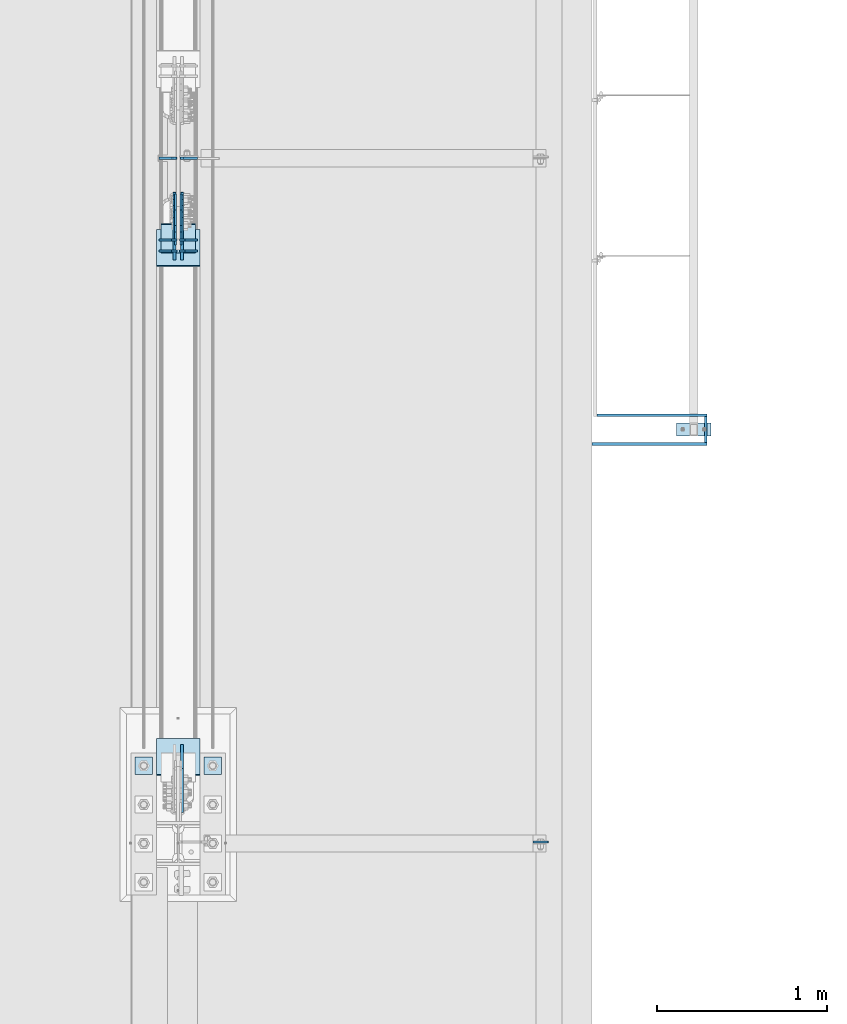
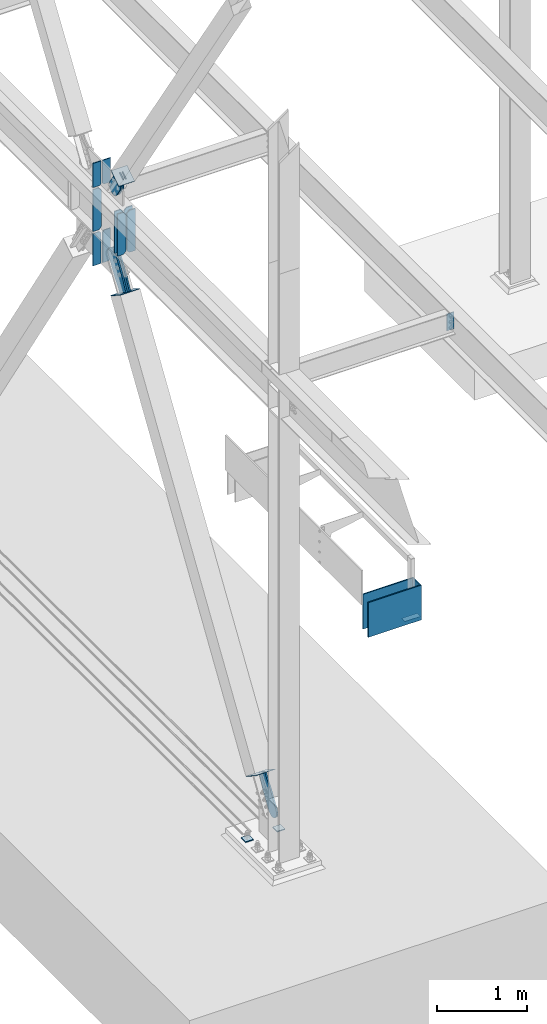
# One storey, part 3331 of 3843: 24 plates, 15 elements without a shape of their own.
"""IFC2X3 building model written with IfcOpenShell, lengths in millimetres."""

from ifc_helpers import new_model, si_unit, frame, origin_with_axes, place, context, subcontext, project, spatial, faceted_brep, material, type_object, element, aggregate, save


model = new_model("IFC2X3")

# Units and contexts
model_context = context("Model", 3, precision=1e-05, world=origin_with_axes())
body_context = subcontext(model_context, "Body", "Model", "MODEL_VIEW")
ifc_project = project(units=[si_unit("LENGTHUNIT", "METRE", prefix="MILLI"), si_unit("AREAUNIT", "SQUARE_METRE"), si_unit("VOLUMEUNIT", "CUBIC_METRE"), si_unit("MASSUNIT", "GRAM", prefix="KILO"), si_unit("TIMEUNIT", "SECOND"), si_unit("PLANEANGLEUNIT", "RADIAN"), si_unit("SOLIDANGLEUNIT", "STERADIAN"), si_unit("THERMODYNAMICTEMPERATUREUNIT", "DEGREE_CELSIUS"), si_unit("LUMINOUSINTENSITYUNIT", "LUMEN")], contexts=[model_context])

# Site, building, storey
site_placement = place(None, origin_with_axes())
site = spatial("IfcSite", under=ifc_project, at=site_placement, CompositionType="ELEMENT")
building_placement = place(site_placement, origin_with_axes())
building = spatial("IfcBuilding", under=site, at=building_placement, Name="Undefined", CompositionType="ELEMENT")
storey_placement = place(building_placement, origin_with_axes())
storey = spatial("IfcBuildingStorey", under=building, at=storey_placement, Name="Undefined", CompositionType="ELEMENT", Elevation=0.0)

# Assembly, plate
assembly_1_placement = place(storey_placement, origin_with_axes())
assembly_1 = element("IfcElementAssembly", 1, at=assembly_1_placement, inside=storey, AssemblyPlace="NOTDEFINED", PredefinedType="NOTDEFINED")
ifc_material_1 = material(Name="Drywall")
plate_type_1 = type_object("IfcPlateType", PredefinedType="NOTDEFINED")
plate_1_placement = place(assembly_1_placement, frame((3101.95308913759, 98996.8516188301, 30714.95), z_axis=(0.999999999468457, -3.26049999966927e-05, 0.0), x_axis=(-3.26049999979655e-05, -0.999999999468457, 0.0)))
plate_1 = element("IfcPlate", 2, at=plate_1_placement, type_object=plate_type_1, material=ifc_material_1, context=body_context, shape_type="Brep", body=[
    faceted_brep([(3.63797880709171e-12, -234.950000000001, -1.45519152283669e-11), (-0.000517728658451233, -234.950000000001, 15.8794303852192), (-0.000517728658451233, 234.950000000001, 15.8794303852192), (3.63797880709171e-12, 234.950000000001, -1.45519152283669e-11), (152.40071802181, -234.950000000001, 15.8843994054114), (152.40071802181, 234.950000000001, 15.8843994054114), (152.401235912494, -234.950000000001, -2.11002770811319e-10), (152.401235912494, 234.950000000001, -2.11002770811319e-10)], [[[0, 1, 2, 3]], [[1, 4, 5, 2]], [[4, 6, 7, 5]], [[6, 0, 3, 7]], [[5, 7, 3, 2]], [[6, 4, 1, 0]]]),
])
aggregate(assembly_1, [plate_1])

assembly_2_placement = place(storey_placement, origin_with_axes())
assembly_2 = element("IfcElementAssembly", 3, at=assembly_2_placement, inside=storey, AssemblyPlace="NOTDEFINED", PredefinedType="NOTDEFINED")
plate_2_placement = place(assembly_2_placement, frame((2438.44525616993, 98828.5999641376, 30714.95), z_axis=(7.63400000505494e-06, 0.999999999970861, 0.0), x_axis=(0.999999999970861, -7.63400000512513e-06, 0.0)))
plate_2 = element("IfcPlate", 4, at=plate_2_placement, type_object=plate_type_1, material=ifc_material_1, context=body_context, shape_type="Brep", body=[
    faceted_brep([(3.63797880709171e-12, -234.950000000001, -1.45519152283669e-11), (-7.41896983527113e-05, -234.950000000001, 15.8794303937975), (-7.41896983527113e-05, 234.950000000001, 15.8794303937975), (3.63797880709171e-12, 234.950000000001, -1.45519152283669e-11), (679.451119685347, -234.950000000001, 15.884399409013), (679.451119685347, 234.950000000001, 15.884399409013), (679.451235852533, -234.950000000001, -4.48198989033699e-09), (679.451235852533, 234.950000000001, -4.48198989033699e-09)], [[[0, 1, 2, 3]], [[1, 4, 5, 2]], [[4, 6, 7, 5]], [[6, 0, 3, 7]], [[5, 7, 3, 2]], [[6, 4, 1, 0]]]),
])
aggregate(assembly_2, [plate_2])

assembly_3_placement = place(storey_placement, origin_with_axes())
assembly_3 = element("IfcElementAssembly", 5, at=assembly_3_placement, inside=storey, AssemblyPlace="NOTDEFINED", PredefinedType="NOTDEFINED")
plate_3_placement = place(assembly_3_placement, frame((2467.02025616993, 98996.8749641376, 30714.95), z_axis=(7.63400000505494e-06, 0.999999999970861, 0.0), x_axis=(0.999999999970861, -7.63400000512513e-06, 0.0)))
plate_3 = element("IfcPlate", 6, at=plate_3_placement, type_object=plate_type_1, material=ifc_material_1, context=body_context, shape_type="Brep", body=[
    faceted_brep([(3.63797880709171e-12, -234.950000000001, -1.45519152283669e-11), (-7.41896983527113e-05, -234.950000000001, 15.8794303937975), (-7.41896983527113e-05, 234.950000000001, 15.8794303937975), (3.63797880709171e-12, 234.950000000001, -1.45519152283669e-11), (650.876114586341, -234.950000000001, 15.884399418268), (650.876114586341, 234.950000000001, 15.884399418268), (650.876235853531, -234.950000000001, 4.65661287307739e-09), (650.876235853531, 234.950000000001, 4.65661287307739e-09)], [[[0, 1, 2, 3]], [[1, 4, 5, 2]], [[4, 6, 7, 5]], [[6, 0, 3, 7]], [[5, 7, 3, 2]], [[6, 4, 1, 0]]]),
])
aggregate(assembly_3, [plate_3])

assembly_4_placement = place(storey_placement, origin_with_axes())
assembly_4 = element("IfcElementAssembly", 7, at=assembly_4_placement, inside=storey, Name="FRAME", AssemblyPlace="NOTDEFINED", PredefinedType="RIGID_FRAME")
ifc_material_2 = material(Name="STEEL/A572-50")
plate_type_2 = type_object("IfcPlateType", PredefinedType="NOTDEFINED")
plate_4_placement = place(assembly_4_placement, frame((3139.678125, 98958.4, 30483.175), z_axis=(0.0, -1.0, 0.0), x_axis=(-1.0, 0.0, 0.0)))
plate_4 = element("IfcPlate", 8, at=plate_4_placement, type_object=plate_type_2, material=ifc_material_2, Name="PLATE", context=body_context, shape_type="Brep", body=[
    faceted_brep([(0.0, -3.17499999999927, 0.0), (0.0, -3.17499999999927, 76.1999969482422), (0.0, 3.17499999999927, 76.1999969482422), (0.0, 3.17499999999927, 0.0), (203.199996948242, -3.17499999999927, 76.1999969482422), (203.199996948242, 3.17499999999927, 76.1999969482422), (203.199996948242, -3.17499999999927, 0.0), (203.199996948242, 3.17499999999927, 0.0)], [[[0, 1, 2, 3]], [[1, 4, 5, 2]], [[4, 6, 7, 5]], [[6, 0, 3, 7]], [[5, 7, 3, 2]], [[6, 4, 1, 0]]]),
])
aggregate(assembly_4, [plate_4])

assembly_5_placement = place(storey_placement, origin_with_axes())
assembly_5 = element("IfcElementAssembly", 9, at=assembly_5_placement, inside=storey, Name="BEAM", AssemblyPlace="NOTDEFINED", PredefinedType="RIGID_FRAME")
plate_type_3 = type_object("IfcPlateType", PredefinedType="NOTDEFINED")
plate_5_placement = place(assembly_5_placement, frame((2180.43125, 96489.8375, 36398.2), z_axis=(-1.0, 0.0, 0.0), x_axis=(0.0, 0.0, -1.0)))
plate_5 = element("IfcPlate", 10, at=plate_5_placement, type_object=plate_type_3, material=ifc_material_2, Name="PLATE", context=body_context, shape_type="Brep", body=[
    faceted_brep([(0.0, -4.76249999999709, 0.0), (0.0, -4.76249999999709, 88.9000015258789), (0.0, 4.76249999999709, 88.9000015258789), (0.0, 4.76249999999709, 0.0), (228.600006102781, -4.7625000004191, 88.9000015257589), (228.600006102781, 4.76249999954598, 88.9000015257443), (228.600006103079, -4.7625000004482, 7.27595761418343e-12), (228.600006103079, 4.76249999954598, -7.27595761418343e-12)], [[[0, 1, 2, 3]], [[1, 4, 5, 2]], [[4, 6, 7, 5]], [[6, 0, 3, 7]], [[5, 7, 3, 2]], [[6, 4, 1, 0]]]),
])
aggregate(assembly_5, [plate_5])

# Assembly, plates
assembly_6_placement = place(storey_placement, origin_with_axes())
assembly_6 = element("IfcElementAssembly", 11, at=assembly_6_placement, inside=storey, Name="BEAM", AssemblyPlace="NOTDEFINED", PredefinedType="RIGID_FRAME")
plate_type_4 = type_object("IfcPlateType", PredefinedType="NOTDEFINED")
plate_6_placement = place(assembly_6_placement, frame((-7.14375000000182, 99973.8183694398, 35840.9875), z_axis=(-1.0, 0.0, 0.0), x_axis=(0.0, 0.0, 1.0)))
plate_6 = element("IfcPlate", 12, at=plate_6_placement, type_object=plate_type_4, material=ifc_material_2, Name="CB_BEAM", context=body_context, shape_type="Brep", body=[
    faceted_brep([(0.0, -6.35000000000582, 31.75), (0.0, -6.35000000000582, 107.15625), (0.0, 6.35000000000582, 107.15625), (0.0, 6.35000000000582, 31.75), (568.324999999997, -6.35000000000582, 107.15625), (568.324999999997, 6.35000000000582, 107.15625), (568.324999999997, -6.35000000000582, 31.75), (568.324999999997, 6.35000000000582, 31.75), (536.574999999997, -6.35000000000582, 0.0), (536.574999999997, 6.35000000000582, 0.0), (31.75, -6.35000000000582, 0.0), (31.75, 6.35000000000582, 0.0)], [[[0, 1, 2, 3]], [[1, 4, 5, 2]], [[4, 6, 7, 5]], [[6, 8, 9, 7]], [[8, 10, 11, 9]], [[10, 0, 3, 11]], [[5, 7, 9, 11, 3, 2]], [[10, 8, 6, 4, 1, 0]]]),
])
plate_7_placement = place(assembly_6_placement, frame((7.14374999999818, 99973.8183694398, 35840.9875), z_axis=(1.0, 0.0, 0.0), x_axis=(0.0, 0.0, 1.0)))
plate_7 = element("IfcPlate", 13, at=plate_7_placement, type_object=plate_type_4, material=ifc_material_2, Name="CB_BEAM", context=body_context, shape_type="Brep", body=[
    faceted_brep([(0.0, -6.35000000000582, 31.75), (0.0, -6.35000000000582, 107.15625), (0.0, 6.35000000000582, 107.15625), (0.0, 6.35000000000582, 31.75), (568.324999999997, -6.35000000000582, 107.15625), (568.324999999997, 6.35000000000582, 107.15625), (568.324999999997, -6.35000000000582, 31.75), (568.324999999997, 6.35000000000582, 31.75), (536.574999999997, -6.35000000000582, 0.0), (536.574999999997, 6.35000000000582, 0.0), (31.75, -6.35000000000582, 0.0), (31.75, 6.35000000000582, 0.0)], [[[0, 1, 2, 3]], [[1, 4, 5, 2]], [[4, 6, 7, 5]], [[6, 8, 9, 7]], [[8, 10, 11, 9]], [[10, 0, 3, 11]], [[5, 7, 9, 11, 3, 2]], [[10, 8, 6, 4, 1, 0]]]),
])
plate_8_placement = place(assembly_6_placement, frame((-7.14375000000182, 100037.574349839, 35840.9875), z_axis=(-1.0, 0.0, 0.0), x_axis=(0.0, 0.0, 1.0)))
plate_8 = element("IfcPlate", 14, at=plate_8_placement, type_object=plate_type_4, material=ifc_material_2, Name="CB_BEAM", context=body_context, shape_type="Brep", body=[
    faceted_brep([(0.0, -6.35000000000582, 31.75), (0.0, -6.35000000000582, 107.15625), (0.0, 6.35000000000582, 107.15625), (0.0, 6.35000000000582, 31.75), (568.324999999997, -6.35000000000582, 107.15625), (568.324999999997, 6.35000000000582, 107.15625), (568.324999999997, -6.35000000000582, 31.75), (568.324999999997, 6.35000000000582, 31.75), (536.574999999997, -6.35000000000582, 0.0), (536.574999999997, 6.35000000000582, 0.0), (31.75, -6.35000000000582, 0.0), (31.75, 6.35000000000582, 0.0)], [[[0, 1, 2, 3]], [[1, 4, 5, 2]], [[4, 6, 7, 5]], [[6, 8, 9, 7]], [[8, 10, 11, 9]], [[10, 0, 3, 11]], [[5, 7, 9, 11, 3, 2]], [[10, 8, 6, 4, 1, 0]]]),
])
plate_9_placement = place(assembly_6_placement, frame((7.14374999999818, 100037.574349839, 35840.9875), z_axis=(1.0, 0.0, 0.0), x_axis=(0.0, 0.0, 1.0)))
plate_9 = element("IfcPlate", 15, at=plate_9_placement, type_object=plate_type_4, material=ifc_material_2, Name="CB_BEAM", context=body_context, shape_type="Brep", body=[
    faceted_brep([(0.0, -6.35000000000582, 31.75), (0.0, -6.35000000000582, 107.15625), (0.0, 6.35000000000582, 107.15625), (0.0, 6.35000000000582, 31.75), (568.324999999997, -6.35000000000582, 107.15625), (568.324999999997, 6.35000000000582, 107.15625), (568.324999999997, -6.35000000000582, 31.75), (568.324999999997, 6.35000000000582, 31.75), (536.574999999997, -6.35000000000582, 0.0), (536.574999999997, 6.35000000000582, 0.0), (31.75, -6.35000000000582, 0.0), (31.75, 6.35000000000582, 0.0)], [[[0, 1, 2, 3]], [[1, 4, 5, 2]], [[4, 6, 7, 5]], [[6, 8, 9, 7]], [[8, 10, 11, 9]], [[10, 0, 3, 11]], [[5, 7, 9, 11, 3, 2]], [[10, 8, 6, 4, 1, 0]]]),
])
plate_10_placement = place(assembly_6_placement, frame((-7.14375000000182, 100520.500001139, 35840.9875), z_axis=(-1.0, 0.0, 0.0), x_axis=(0.0, 0.0, 1.0)))
plate_10 = element("IfcPlate", 16, at=plate_10_placement, type_object=plate_type_4, material=ifc_material_2, Name="CB_BEAM", context=body_context, shape_type="Brep", body=[
    faceted_brep([(0.0, -6.35000000000582, 31.75), (0.0, -6.35000000000582, 107.15625), (0.0, 6.35000000000582, 107.15625), (0.0, 6.35000000000582, 31.75), (568.324999999997, -6.35000000000582, 107.15625), (568.324999999997, 6.35000000000582, 107.15625), (568.324999999997, -6.35000000000582, 31.75), (568.324999999997, 6.35000000000582, 31.75), (536.574999999997, -6.35000000000582, 0.0), (536.574999999997, 6.35000000000582, 0.0), (31.75, -6.35000000000582, 0.0), (31.75, 6.35000000000582, 0.0)], [[[0, 1, 2, 3]], [[1, 4, 5, 2]], [[4, 6, 7, 5]], [[6, 8, 9, 7]], [[8, 10, 11, 9]], [[10, 0, 3, 11]], [[5, 7, 9, 11, 3, 2]], [[10, 8, 6, 4, 1, 0]]]),
])
plate_type_5 = type_object("IfcPlateType", PredefinedType="NOTDEFINED")
plate_11_placement = place(assembly_6_placement, frame((-9.525, 100520.500001139, 36436.3), z_axis=(-1.0, 0.0, 0.0), x_axis=(0.0, 0.0, 1.0)))
plate_11 = element("IfcPlate", 17, at=plate_11_placement, type_object=plate_type_5, material=ifc_material_2, Name="CB", context=body_context, shape_type="Brep", body=[
    faceted_brep([(0.0, -6.34999999999854, 19.0499992370605), (0.0, -6.34999999999854, 104.775000000009), (0.0, 6.34999999999854, 104.775000000009), (0.0, 6.34999999999854, 19.0499992370605), (327.523369235896, -6.35000000000582, 104.775), (327.523369235896, 6.35000000000582, 104.775), (327.523369235896, -6.35000000000582, 0.0), (327.523369235896, 6.35000000000582, 0.0), (19.0499992370605, -6.34999999999854, 0.0), (19.0499992370605, 6.34999999999854, 0.0)], [[[0, 1, 2, 3]], [[1, 4, 5, 2]], [[4, 6, 7, 5]], [[6, 8, 9, 7]], [[8, 0, 3, 9]], [[5, 7, 9, 3, 2]], [[8, 6, 4, 1, 0]]]),
])
plate_12_placement = place(assembly_6_placement, frame((9.525, 100520.500001139, 36436.3), z_axis=(1.0, 0.0, 0.0), x_axis=(0.0, 0.0, 1.0)))
plate_12 = element("IfcPlate", 18, at=plate_12_placement, type_object=plate_type_5, material=ifc_material_2, Name="CB", context=body_context, shape_type="Brep", body=[
    faceted_brep([(0.0, -6.34999999999854, 19.0499992370605), (0.0, -6.34999999999854, 104.775000000009), (0.0, 6.34999999999854, 104.775000000009), (0.0, 6.34999999999854, 19.0499992370605), (327.523369235896, -6.35000000000582, 104.775), (327.523369235896, 6.35000000000582, 104.775), (327.523369235896, -6.35000000000582, 0.0), (327.523369235896, 6.35000000000582, 0.0), (19.0499992370605, -6.34999999999854, 0.0), (19.0499992370605, 6.34999999999854, 0.0)], [[[0, 1, 2, 3]], [[1, 4, 5, 2]], [[4, 6, 7, 5]], [[6, 8, 9, 7]], [[8, 0, 3, 9]], [[5, 7, 9, 3, 2]], [[8, 6, 4, 1, 0]]]),
])

# Assembly, plate
assembly_7_placement = place(storey_placement, origin_with_axes())
assembly_7 = element("IfcElementAssembly", 19, at=assembly_7_placement, inside=storey, AssemblyPlace="NOTDEFINED", PredefinedType="RIGID_FRAME")
ifc_material_3 = material(Name="STEEL/A36")
plate_type_6 = type_object("IfcPlateType", PredefinedType="NOTDEFINED")
plate_13_placement = place(assembly_7_placement, frame((-15.875, 100084.274066612, 36868.2083362885), z_axis=(0.0, -0.83424452268884, -0.551394664794346), x_axis=(0.0, 0.551394664794348, -0.834244522688839)))
plate_13 = element("IfcPlate", 20, at=plate_13_placement, type_object=plate_type_6, material=ifc_material_3, context=body_context, shape_type="Brep", body=[
    faceted_brep([(0.0, -6.3499999046162, 0.0), (2.18278728425503e-10, -6.35000000000582, 91.5986124321353), (2.18278728425503e-10, 6.35000000000582, 91.5986124321353), (7.27595761418343e-12, 6.3499999046162, 0.0), (69.8499999987471, -6.35000000000582, 91.598612432037), (69.8499999987471, 6.35000000000582, 91.598612432037), (171.44999999673, -6.35000000000582, 136.286806214401), (171.44999999673, 6.35000000000582, 136.286806214401), (316.534985839971, -6.35000000000582, 136.286806214212), (316.534985839971, 6.35000000000582, 136.286806214212), (351.163054093879, -6.35000000000582, 129.398855179952), (351.163054093879, 6.35000000000582, 129.398855179952), (380.51931286032, -6.35000000000582, 109.783630182814), (380.51931286032, 6.35000000000582, 109.783630182814), (400.134537857251, -6.35000000000582, 80.42737141615), (400.134537857251, 6.35000000000582, 80.42737141615), (407.022488891344, -6.35000000000582, 45.7993092690485), (407.022488891344, 6.35000000000582, 45.7993092690485), (400.134537857084, -6.35000000000582, 11.1712410149557), (400.134537857084, 6.35000000000582, 11.1712410149557), (380.519312860015, -6.35000000000582, -18.1850177516608), (380.519312860015, 6.35000000000582, -18.1850177516608), (351.163054093486, -6.35000000000582, -37.8002427487263), (351.163054093486, 6.35000000000582, -37.8002427487263), (316.534988893036, -6.35000000000582, -44.6881937828948), (316.534988893036, 6.35000000000582, -44.6881937828948), (171.449999996279, -6.35000000000582, -44.6881937827056), (171.449999996279, 6.35000000000582, -44.6881937827056), (69.8499999985434, -6.35000000000582, -8.73114913702011e-11), (69.8499999985434, 6.35000000000582, -8.73114913702011e-11)], [[[0, 1, 2, 3]], [[1, 4, 5, 2]], [[4, 6, 7, 5]], [[6, 8, 9, 7]], [[8, 10, 11, 9]], [[10, 12, 13, 11]], [[12, 14, 15, 13]], [[14, 16, 17, 15]], [[16, 18, 19, 17]], [[18, 20, 21, 19]], [[20, 22, 23, 21]], [[22, 24, 25, 23]], [[24, 26, 27, 25]], [[26, 28, 29, 27]], [[28, 0, 3, 29]], [[5, 7, 9, 11, 13, 15, 17, 19, 21, 23, 25, 27, 29, 3, 2]], [[28, 26, 24, 22, 20, 18, 16, 14, 12, 10, 8, 6, 4, 1, 0]]]),
])
aggregate(assembly_7, [plate_13])

assembly_8_placement = place(storey_placement, origin_with_axes())
assembly_8 = element("IfcElementAssembly", 21, at=assembly_8_placement, inside=storey, AssemblyPlace="NOTDEFINED", PredefinedType="RIGID_FRAME")
plate_14_placement = place(assembly_8_placement, frame((15.875, 100084.274066612, 36868.2083362885), z_axis=(0.0, -0.83424452268884, -0.551394664794346), x_axis=(0.0, 0.551394664794348, -0.834244522688839)))
plate_14 = element("IfcPlate", 22, at=plate_14_placement, type_object=plate_type_6, material=ifc_material_3, context=body_context, shape_type="Brep", body=[
    faceted_brep([(0.0, -6.3499999046162, 0.0), (2.18278728425503e-10, -6.35000000000582, 91.5986124321353), (2.18278728425503e-10, 6.35000000000582, 91.5986124321353), (7.27595761418343e-12, 6.3499999046162, 0.0), (69.8499999987471, -6.35000000000582, 91.598612432037), (69.8499999987471, 6.35000000000582, 91.598612432037), (171.44999999673, -6.35000000000582, 136.286806214401), (171.44999999673, 6.35000000000582, 136.286806214401), (316.534985839971, -6.35000000000582, 136.286806214212), (316.534985839971, 6.35000000000582, 136.286806214212), (351.163054093879, -6.35000000000582, 129.398855179952), (351.163054093879, 6.35000000000582, 129.398855179952), (380.51931286032, -6.35000000000582, 109.783630182814), (380.51931286032, 6.35000000000582, 109.783630182814), (400.134537857251, -6.35000000000582, 80.42737141615), (400.134537857251, 6.35000000000582, 80.42737141615), (407.022488891344, -6.35000000000582, 45.7993092690485), (407.022488891344, 6.35000000000582, 45.7993092690485), (400.134537857084, -6.35000000000582, 11.1712410149557), (400.134537857084, 6.35000000000582, 11.1712410149557), (380.519312860015, -6.35000000000582, -18.1850177516608), (380.519312860015, 6.35000000000582, -18.1850177516608), (351.163054093486, -6.35000000000582, -37.8002427487263), (351.163054093486, 6.35000000000582, -37.8002427487263), (316.534988893036, -6.35000000000582, -44.6881937828948), (316.534988893036, 6.35000000000582, -44.6881937828948), (171.449999996279, -6.35000000000582, -44.6881937827056), (171.449999996279, 6.35000000000582, -44.6881937827056), (69.8499999985434, -6.35000000000582, -8.73114913702011e-11), (69.8499999985434, 6.35000000000582, -8.73114913702011e-11)], [[[0, 1, 2, 3]], [[1, 4, 5, 2]], [[4, 6, 7, 5]], [[6, 8, 9, 7]], [[8, 10, 11, 9]], [[10, 12, 13, 11]], [[12, 14, 15, 13]], [[14, 16, 17, 15]], [[16, 18, 19, 17]], [[18, 20, 21, 19]], [[20, 22, 23, 21]], [[22, 24, 25, 23]], [[24, 26, 27, 25]], [[26, 28, 29, 27]], [[28, 0, 3, 29]], [[5, 7, 9, 11, 13, 15, 17, 19, 21, 23, 25, 27, 29, 3, 2]], [[28, 26, 24, 22, 20, 18, 16, 14, 12, 10, 8, 6, 4, 1, 0]]]),
])
aggregate(assembly_8, [plate_14])

assembly_9_placement = place(storey_placement, origin_with_axes())
assembly_9 = element("IfcElementAssembly", 23, at=assembly_9_placement, inside=storey, Name="Plate", AssemblyPlace="NOTDEFINED", PredefinedType="RIGID_FRAME")
plate_type_7 = type_object("IfcPlateType", PredefinedType="NOTDEFINED")
plate_15_placement = place(assembly_9_placement, frame((-101.6, 99963.057681007, 36784.2844189205), z_axis=(0.0, 0.83424452268884, 0.551394664794346), x_axis=(1.0, 0.0, 0.0)))
plate_15 = element("IfcPlate", 24, at=plate_15_placement, type_object=plate_type_7, material=ifc_material_3, Name="Plate", context=body_context, shape_type="Brep", body=[
    faceted_brep([(0.0, -3.17499999999927, 0.0), (0.0, -3.17500000043947, 203.200000001736), (0.0, 3.1749999995518, 203.200000001743), (0.0, 3.17499999999927, 0.0), (203.200000000012, -3.17500000043947, 203.200000001736), (203.200000000012, 3.1749999995518, 203.200000001743), (203.199996948242, -3.17499999999927, 0.0), (203.199996948242, 3.17499999999927, 0.0)], [[[0, 1, 2, 3]], [[1, 4, 5, 2]], [[4, 6, 7, 5]], [[6, 0, 3, 7]], [[5, 7, 3, 2]], [[6, 4, 1, 0]]]),
])
aggregate(assembly_9, [plate_15])

# Plate
plate_type_8 = type_object("IfcPlateType", PredefinedType="NOTDEFINED")
plate_16_placement = place(assembly_6_placement, frame((-12.7000000000007, 100520.500001139, 35376.246875), z_axis=(-1.0, 0.0, 0.0), x_axis=(0.0, 0.0, 1.0)))
plate_16 = element("IfcPlate", 25, at=plate_16_placement, type_object=plate_type_8, material=ifc_material_2, Name="CB", context=body_context, shape_type="Brep", body=[
    faceted_brep([(0.0, -6.3499999046162, 0.0), (-1.67347025126219e-10, -6.35000000000582, 101.600000000151), (-1.67347025126219e-10, 6.35000000000582, 101.600000000151), (7.27595761418343e-12, 6.3499999046162, 0.0), (437.695003599103, -6.35000000000582, 101.6), (437.695003599103, 6.35000000000582, 101.6), (437.695003599103, -6.35000000000582, 19.0499992370605), (437.695003599103, 6.35000000000582, 19.0499992370605), (418.645004362043, -6.35000000000582, 0.0), (418.645004362043, 6.35000000000582, 0.0)], [[[0, 1, 2, 3]], [[1, 4, 5, 2]], [[4, 6, 7, 5]], [[6, 8, 9, 7]], [[8, 0, 3, 9]], [[5, 7, 9, 3, 2]], [[8, 6, 4, 1, 0]]]),
])

plate_17_placement = place(assembly_6_placement, frame((12.7000000000007, 100520.500001139, 35376.246875), z_axis=(1.0, 0.0, 0.0), x_axis=(0.0, 0.0, 1.0)))
plate_17 = element("IfcPlate", 26, at=plate_17_placement, type_object=plate_type_8, material=ifc_material_2, Name="CB", context=body_context, shape_type="Brep", body=[
    faceted_brep([(0.0, -6.3499999046162, 0.0), (-1.67347025126219e-10, -6.35000000000582, 101.600000000151), (-1.67347025126219e-10, 6.35000000000582, 101.600000000151), (7.27595761418343e-12, 6.3499999046162, 0.0), (437.695003599103, -6.35000000000582, 101.6), (437.695003599103, 6.35000000000582, 101.6), (437.695003599103, -6.35000000000582, 19.0499992370605), (437.695003599103, 6.35000000000582, 19.0499992370605), (418.645004362043, -6.35000000000582, 0.0), (418.645004362043, 6.35000000000582, 0.0)], [[[0, 1, 2, 3]], [[1, 4, 5, 2]], [[4, 6, 7, 5]], [[6, 8, 9, 7]], [[8, 0, 3, 9]], [[5, 7, 9, 3, 2]], [[8, 6, 4, 1, 0]]]),
])

aggregate(assembly_6, [plate_6, plate_7, plate_8, plate_9, plate_11, plate_12, plate_10, plate_16, plate_17])

# Assembly, plates
assembly_10_placement = place(storey_placement, origin_with_axes())
assembly_10 = element("IfcElementAssembly", 27, at=assembly_10_placement, inside=storey, Name="TEMPLATE", AssemblyPlace="NOTDEFINED", PredefinedType="RIGID_FRAME")
plate_18_placement = place(assembly_10_placement, frame((-152.4, 96989.9, 29825.95), z_axis=(-1.0, 0.0, 0.0), x_axis=(0.0, -1.0, 0.0)))
plate_18 = element("IfcPlate", 28, at=plate_18_placement, type_object=plate_type_8, material=ifc_material_2, Name="Washer Plate", context=body_context, shape_type="Brep", body=[
    faceted_brep([(0.0, -6.3499999046162, 0.0), (-1.67347025126219e-10, -6.35000000000582, 101.600000000151), (-1.67347025126219e-10, 6.35000000000582, 101.600000000151), (7.27595761418343e-12, 6.3499999046162, 0.0), (101.599998474121, -6.34999999999854, 101.599998474121), (101.599998474121, 6.34999999999854, 101.599998474121), (101.6, -6.34999999999854, 0.0), (101.6, 6.34999999999854, 0.0)], [[[0, 1, 2, 3]], [[1, 4, 5, 2]], [[4, 6, 7, 5]], [[6, 0, 3, 7]], [[5, 7, 3, 2]], [[6, 4, 1, 0]]]),
])
plate_19_placement = place(assembly_10_placement, frame((254.0, 96989.9, 29825.95), z_axis=(-1.0, 0.0, 0.0), x_axis=(0.0, -1.0, 0.0)))
plate_19 = element("IfcPlate", 29, at=plate_19_placement, type_object=plate_type_8, material=ifc_material_2, Name="Washer Plate", context=body_context, shape_type="Brep", body=[
    faceted_brep([(0.0, -6.3499999046162, 0.0), (-1.67347025126219e-10, -6.35000000000582, 101.600000000151), (-1.67347025126219e-10, 6.35000000000582, 101.600000000151), (7.27595761418343e-12, 6.3499999046162, 0.0), (101.599998474121, -6.34999999999854, 101.599998474121), (101.599998474121, 6.34999999999854, 101.599998474121), (101.6, -6.34999999999854, 0.0), (101.6, 6.34999999999854, 0.0)], [[[0, 1, 2, 3]], [[1, 4, 5, 2]], [[4, 6, 7, 5]], [[6, 0, 3, 7]], [[5, 7, 3, 2]], [[6, 4, 1, 0]]]),
])
aggregate(assembly_10, [plate_18, plate_19])

# Assembly, plate
assembly_11_placement = place(storey_placement, origin_with_axes())
assembly_11 = element("IfcElementAssembly", 30, at=assembly_11_placement, inside=storey, AssemblyPlace="NOTDEFINED", PredefinedType="RIGID_FRAME")
plate_type_9 = type_object("IfcPlateType", PredefinedType="NOTDEFINED")
plate_20_placement = place(assembly_11_placement, frame((-22.225, 100061.798640642, 35252.2765036908), z_axis=(0.0, -0.84208653813787, 0.539342435088301), x_axis=(0.0, 0.539342435088305, 0.842086538137867)))
plate_20 = element("IfcPlate", 31, at=plate_20_placement, type_object=plate_type_9, material=ifc_material_3, context=body_context, shape_type="Brep", body=[
    faceted_brep([(0.0, -9.52500000000146, 0.0), (-2.16823536902666e-09, -9.52499999999418, 169.022957228546), (-2.16823536902666e-09, 9.52499999999418, 169.022957228546), (0.0, 9.52500000000146, 0.0), (69.8499999974956, -9.52499999999418, 169.02295722875), (69.8499999974956, 9.52499999999418, 169.02295722875), (171.449999996829, -9.52499999999418, 181.348978614493), (171.449999996829, 9.52499999999418, 181.348978614493), (434.579297661258, -9.52499999999418, 181.348978615235), (434.579297661258, 9.52499999999418, 181.348978615235), (471.63740512668, -9.52499999999418, 173.977662728823), (471.63740512668, 9.52499999999418, 173.977662728823), (503.053751663178, -9.52499999999418, 152.985931091971), (503.053751663178, 9.52499999999418, 152.985931091971), (524.045483300536, -9.52499999999418, 121.569584555793), (524.045483300536, 9.52499999999418, 121.569584555793), (531.416799187516, -9.52499999999418, 84.511480142959), (531.416799187516, 9.52499999999418, 84.511480142959), (524.0454833013, -9.52499999999418, 47.4533726770169), (524.0454833013, 9.52499999999418, 47.4533726770169), (503.053751664252, -9.52499999999418, 16.0370261400676), (503.053751664252, 9.52499999999418, 16.0370261400676), (471.63740512763, -9.52499999999418, -4.95470549746824), (471.63740512763, 9.52499999999418, -4.95470549746824), (434.579299189239, -9.52499999999418, -12.3260213842586), (434.579299189239, 9.52499999999418, -12.3260213842586), (171.44999999931, -9.52499999999418, -12.3260213849862), (171.44999999931, 9.52499999999418, -12.3260213849862), (69.8499999979995, -9.52499999999418, -4.00177668780088e-10), (69.8499999979995, 9.52499999999418, -4.00177668780088e-10)], [[[0, 1, 2, 3]], [[1, 4, 5, 2]], [[4, 6, 7, 5]], [[6, 8, 9, 7]], [[8, 10, 11, 9]], [[10, 12, 13, 11]], [[12, 14, 15, 13]], [[14, 16, 17, 15]], [[16, 18, 19, 17]], [[18, 20, 21, 19]], [[20, 22, 23, 21]], [[22, 24, 25, 23]], [[24, 26, 27, 25]], [[26, 28, 29, 27]], [[28, 0, 3, 29]], [[5, 7, 9, 11, 13, 15, 17, 19, 21, 23, 25, 27, 29, 3, 2]], [[28, 26, 24, 22, 20, 18, 16, 14, 12, 10, 8, 6, 4, 1, 0]]]),
])
aggregate(assembly_11, [plate_20])

assembly_12_placement = place(storey_placement, origin_with_axes())
assembly_12 = element("IfcElementAssembly", 32, at=assembly_12_placement, inside=storey, AssemblyPlace="NOTDEFINED", PredefinedType="RIGID_FRAME")
plate_21_placement = place(assembly_12_placement, frame((22.225, 100061.798640642, 35252.2765036908), z_axis=(0.0, -0.84208653813787, 0.539342435088301), x_axis=(0.0, 0.539342435088305, 0.842086538137867)))
plate_21 = element("IfcPlate", 33, at=plate_21_placement, type_object=plate_type_9, material=ifc_material_3, context=body_context, shape_type="Brep", body=[
    faceted_brep([(0.0, -9.52500000000146, 0.0), (-2.16823536902666e-09, -9.52499999999418, 169.022957228546), (-2.16823536902666e-09, 9.52499999999418, 169.022957228546), (0.0, 9.52500000000146, 0.0), (69.8499999974956, -9.52499999999418, 169.02295722875), (69.8499999974956, 9.52499999999418, 169.02295722875), (171.449999996829, -9.52499999999418, 181.348978614493), (171.449999996829, 9.52499999999418, 181.348978614493), (434.579297661258, -9.52499999999418, 181.348978615235), (434.579297661258, 9.52499999999418, 181.348978615235), (471.63740512668, -9.52499999999418, 173.977662728823), (471.63740512668, 9.52499999999418, 173.977662728823), (503.053751663178, -9.52499999999418, 152.985931091971), (503.053751663178, 9.52499999999418, 152.985931091971), (524.045483300536, -9.52499999999418, 121.569584555793), (524.045483300536, 9.52499999999418, 121.569584555793), (531.416799187516, -9.52499999999418, 84.511480142959), (531.416799187516, 9.52499999999418, 84.511480142959), (524.0454833013, -9.52499999999418, 47.4533726770169), (524.0454833013, 9.52499999999418, 47.4533726770169), (503.053751664252, -9.52499999999418, 16.0370261400676), (503.053751664252, 9.52499999999418, 16.0370261400676), (471.63740512763, -9.52499999999418, -4.95470549746824), (471.63740512763, 9.52499999999418, -4.95470549746824), (434.579299189239, -9.52499999999418, -12.3260213842586), (434.579299189239, 9.52499999999418, -12.3260213842586), (171.44999999931, -9.52499999999418, -12.3260213849862), (171.44999999931, 9.52499999999418, -12.3260213849862), (69.8499999979995, -9.52499999999418, -4.00177668780088e-10), (69.8499999979995, 9.52499999999418, -4.00177668780088e-10)], [[[0, 1, 2, 3]], [[1, 4, 5, 2]], [[4, 6, 7, 5]], [[6, 8, 9, 7]], [[8, 10, 11, 9]], [[10, 12, 13, 11]], [[12, 14, 15, 13]], [[14, 16, 17, 15]], [[16, 18, 19, 17]], [[18, 20, 21, 19]], [[20, 22, 23, 21]], [[22, 24, 25, 23]], [[24, 26, 27, 25]], [[26, 28, 29, 27]], [[28, 0, 3, 29]], [[5, 7, 9, 11, 13, 15, 17, 19, 21, 23, 25, 27, 29, 3, 2]], [[28, 26, 24, 22, 20, 18, 16, 14, 12, 10, 8, 6, 4, 1, 0]]]),
])
aggregate(assembly_12, [plate_21])

assembly_13_placement = place(storey_placement, origin_with_axes())
assembly_13 = element("IfcElementAssembly", 34, at=assembly_13_placement, inside=storey, AssemblyPlace="NOTDEFINED", PredefinedType="RIGID_FRAME")
plate_22_placement = place(assembly_13_placement, frame((22.225, 97027.4041665625, 30514.6134314622), z_axis=(0.0, -0.84208653813787, 0.539342435088301), x_axis=(0.0, 0.539342435088305, 0.842086538137867)))
plate_22 = element("IfcPlate", 35, at=plate_22_placement, type_object=plate_type_9, material=ifc_material_3, context=body_context, shape_type="Brep", body=[
    faceted_brep([(0.0, -9.52500000000146, 0.0), (-101.599999999351, -9.52499999999418, -12.3260213857429), (-101.599999999351, 9.52499999999418, -12.3260213857429), (0.0, 9.52500000000146, 0.0), (-364.729297663791, -9.52499999999418, -12.3260213864851), (-364.729297663791, 9.52499999999418, -12.3260213864851), (-401.787405129209, -9.52499999999418, -4.95470550008758), (-401.787405129209, 9.52499999999418, -4.95470550008758), (-433.203751665707, -9.52499999999418, 16.0370261367789), (-433.203751665707, 9.52499999999418, 16.0370261367789), (-454.195483303061, -9.52499999999418, 47.4533726729569), (-454.195483303061, 9.52499999999418, 47.4533726729569), (-461.566799190045, -9.52499999999418, 84.5114770857908), (-461.566799190045, 9.52499999999418, 84.5114770857908), (-454.195483303822, -9.52499999999418, 121.569584551733), (-454.195483303822, 9.52499999999418, 121.569584551733), (-433.203751666773, -9.52499999999418, 152.985931088682), (-433.203751666773, 9.52499999999418, 152.985931088682), (-401.787405130151, -9.52499999999418, 173.977662726218), (-401.787405130151, 9.52499999999418, 173.977662726218), (-364.729299191746, -9.52499999999418, 181.348978613009), (-364.729299191746, 9.52499999999418, 181.348978613009), (-101.600000001839, -9.52499999999418, 181.348978613736), (-101.600000001839, 9.52499999999418, 181.348978613736), (-2.16823536902666e-09, -9.52499999999418, 169.022957228546), (-2.16823536902666e-09, 9.52499999999418, 169.022957228546), (69.8499999974956, -9.52499999999418, 169.02295722875), (69.8499999974956, 9.52499999999418, 169.02295722875), (69.8499999979995, -9.52499999999418, -4.00177668780088e-10), (69.8499999979995, 9.52499999999418, -4.00177668780088e-10)], [[[0, 1, 2, 3]], [[1, 4, 5, 2]], [[4, 6, 7, 5]], [[6, 8, 9, 7]], [[8, 10, 11, 9]], [[10, 12, 13, 11]], [[12, 14, 15, 13]], [[14, 16, 17, 15]], [[16, 18, 19, 17]], [[18, 20, 21, 19]], [[20, 22, 23, 21]], [[22, 24, 25, 23]], [[24, 26, 27, 25]], [[26, 28, 29, 27]], [[28, 0, 3, 29]], [[5, 7, 9, 11, 13, 15, 17, 19, 21, 23, 25, 27, 29, 3, 2]], [[28, 26, 24, 22, 20, 18, 16, 14, 12, 10, 8, 6, 4, 1, 0]]]),
])
aggregate(assembly_13, [plate_22])

assembly_14_placement = place(storey_placement, origin_with_axes())
assembly_14 = element("IfcElementAssembly", 36, at=assembly_14_placement, inside=storey, Name="Plate", AssemblyPlace="NOTDEFINED", PredefinedType="RIGID_FRAME")
plate_type_10 = type_object("IfcPlateType", PredefinedType="NOTDEFINED")
plate_23_placement = place(assembly_14_placement, frame((127.0, 100099.290064714, 35232.0342658727), z_axis=(0.0, -0.84208653813787, 0.539342435088301), x_axis=(-1.0, 0.0, 0.0)))
plate_23 = element("IfcPlate", 37, at=plate_23_placement, type_object=plate_type_10, material=ifc_material_3, Name="Plate", context=body_context, shape_type="Brep", body=[
    faceted_brep([(0.0, -3.17499999999927, 0.0), (0.0, -3.17499999965185, 254.000000005151), (0.0, 3.17500000035216, 254.000000005166), (0.0, 3.17499999999927, 0.0), (254.0, -3.17499999965185, 254.000000005151), (254.0, 3.17500000035216, 254.000000005166), (254.0, -3.17500000000291, 0.0), (254.0, 3.17499999999927, 1.45519152283669e-11)], [[[0, 1, 2, 3]], [[1, 4, 5, 2]], [[4, 6, 7, 5]], [[6, 0, 3, 7]], [[5, 7, 3, 2]], [[6, 4, 1, 0]]]),
])
aggregate(assembly_14, [plate_23])

assembly_15_placement = place(storey_placement, origin_with_axes())
assembly_15 = element("IfcElementAssembly", 38, at=assembly_15_placement, inside=storey, Name="Plate", AssemblyPlace="NOTDEFINED", PredefinedType="RIGID_FRAME")
plate_24_placement = place(assembly_15_placement, frame((127.0, 97099.1438352771, 30547.8436888265), z_axis=(0.0, -0.84208653813787, 0.539342435088301), x_axis=(-1.0, 0.0, 0.0)))
plate_24 = element("IfcPlate", 39, at=plate_24_placement, type_object=plate_type_10, material=ifc_material_3, Name="Plate", context=body_context, shape_type="Brep", body=[
    faceted_brep([(0.0, -3.17499999999927, 0.0), (0.0, -3.17499999965185, 254.000000005151), (0.0, 3.17500000035216, 254.000000005166), (0.0, 3.17499999999927, 0.0), (254.0, -3.17499999965185, 254.000000005151), (254.0, 3.17500000035216, 254.000000005166), (254.0, -3.17500000000291, 0.0), (254.0, 3.17499999999927, 1.45519152283669e-11)], [[[0, 1, 2, 3]], [[1, 4, 5, 2]], [[4, 6, 7, 5]], [[6, 0, 3, 7]], [[5, 7, 3, 2]], [[6, 4, 1, 0]]]),
])
aggregate(assembly_15, [plate_24])

save(model, "model.ifc")
